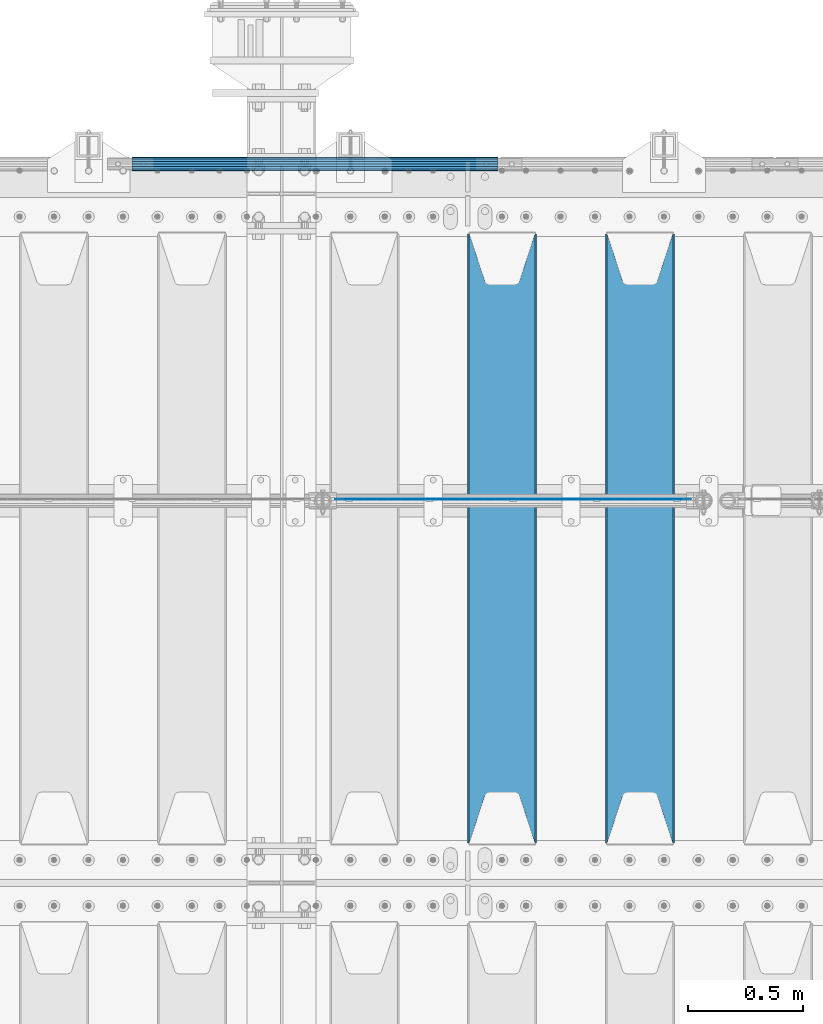
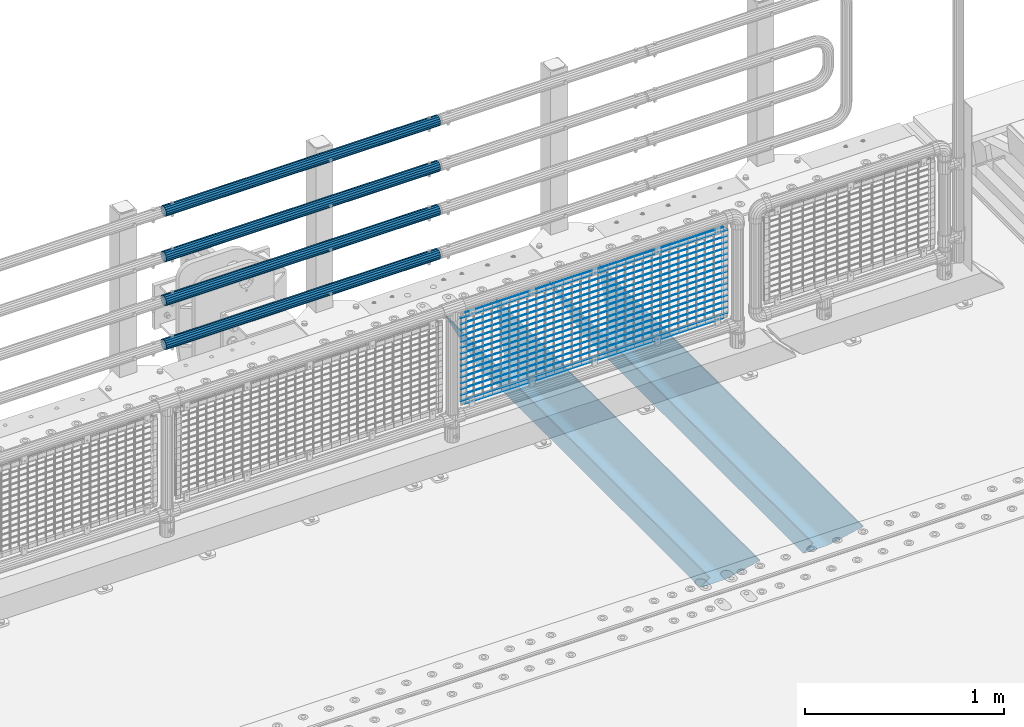
# One storey, part 116 of 219: 23 beams.
"""IFC2X3 building model written with IfcOpenShell, lengths in millimetres."""

import ifcopenshell
import ifcopenshell.guid

model = None  # the IFC model being written
_history = None  # IfcOwnerHistory: only IFC2X3 demands one
_inside = {}  # id of a spatial element -> (the spatial element, [elements in it])
_under = {}  # id of a project, library or spatial element -> (it, [spatial elements below it])
_declared = {}  # id of a project -> (the project, [libraries it declares])
_typed = {}  # id of a type object -> (the type object, [elements of that type])
_made_of = {}  # id of a material, layer set ... -> (it, [elements and type objects made of it])


def new_model(schema):
    """Start an empty IFC model of exactly this schema.

    Asked for "IFC4X3", IfcOpenShell would pick the latest addendum, in which some entities
    have other attributes; the version numbers below select the first issue.
    IFC2X3 requires an IfcOwnerHistory on every rooted entity: one is made here for all.
    """
    global model, _history
    if schema == "IFC4X3":
        model = ifcopenshell.file(schema_version=(4, 3, 0, 0))
    else:
        model = ifcopenshell.file(schema=schema)
    _inside.clear()
    _under.clear()
    _declared.clear()
    _typed.clear()
    _made_of.clear()
    _history = None
    if model.schema == "IFC2X3":
        org = make("IfcOrganization", Name="unknown")
        user = make(
            "IfcPersonAndOrganization",
            ThePerson=make("IfcPerson", FamilyName="unknown"),
            TheOrganization=org,
        )
        app = make(
            "IfcApplication",
            ApplicationDeveloper=org,
            Version="unknown",
            ApplicationFullName="unknown",
            ApplicationIdentifier="unknown",
        )
        _history = make(
            "IfcOwnerHistory",
            OwningUser=user,
            OwningApplication=app,
            ChangeAction="ADDED",
            CreationDate=0,
        )
    return model


def make(cls, **values):
    """One entity of the class cls with the attributes given. An attribute that is None is left unset."""
    return model.create_entity(
        cls, **{name: value for name, value in values.items() if value is not None}
    )


def rooted(cls, **values):
    """An entity with a GlobalId (a new one), such as an element, a storey or a relation."""
    return make(cls, GlobalId=ifcopenshell.guid.new(), OwnerHistory=_history, **values)


def si_unit(unit_type, name, prefix=None):
    """IfcSIUnit, for example si_unit("LENGTHUNIT", "METRE", prefix="MILLI")."""
    return make("IfcSIUnit", UnitType=unit_type, Prefix=prefix, Name=name)


def assignment(units):
    """IfcUnitAssignment: the units of a project."""
    return None if units is None else make("IfcUnitAssignment", Units=units)


def point(xyz):
    """IfcCartesianPoint."""
    return None if xyz is None else make("IfcCartesianPoint", Coordinates=xyz)


def direction(xyz):
    """IfcDirection."""
    return None if xyz is None else make("IfcDirection", DirectionRatios=xyz)


def frame(location, z_axis=None, x_axis=None):
    """IfcAxis2Placement3D, a coordinate frame: its origin and axes. An axis left out is left unset."""
    return make(
        "IfcAxis2Placement3D",
        Location=point(location),
        Axis=direction(z_axis),
        RefDirection=direction(x_axis),
    )


def origin_with_axes():
    """The frame at (0, 0, 0) with the z axis (0, 0, 1) and the x axis (1, 0, 0) written out."""
    return frame((0.0, 0.0, 0.0), z_axis=(0.0, 0.0, 1.0), x_axis=(1.0, 0.0, 0.0))


def place(relative_to, where):
    """IfcLocalPlacement: puts the frame where relative to a parent placement (None: the world)."""
    return make(
        "IfcLocalPlacement", PlacementRelTo=relative_to, RelativePlacement=where
    )


def context(
    kind, dimensions, precision=None, world=None, true_north=None, identifier=None
):
    """IfcGeometricRepresentationContext, for example the 3D "Model" context."""
    return make(
        "IfcGeometricRepresentationContext",
        ContextIdentifier=identifier,
        ContextType=kind,
        CoordinateSpaceDimension=dimensions,
        Precision=precision,
        WorldCoordinateSystem=world,
        TrueNorth=true_north,
    )


def subcontext(parent, identifier, kind, view, scale=None):
    """IfcGeometricRepresentationSubContext, for example "Body" below "Model"."""
    return make(
        "IfcGeometricRepresentationSubContext",
        ContextIdentifier=identifier,
        ContextType=kind,
        ParentContext=parent,
        TargetScale=scale,
        TargetView=view,
    )


def project(units=None, contexts=None):
    """IfcProject with its units and contexts."""
    return rooted(
        "IfcProject",
        Name="project",
        RepresentationContexts=contexts,
        UnitsInContext=assignment(units),
    )


def spatial(cls, under=None, at=None, **own):
    """A site, building, storey or space (cls), placed at a placement, below another one or the project."""
    s = rooted(cls, ObjectPlacement=at, **own)
    if under is not None:
        _under.setdefault(under.id(), (under, []))[1].append(s)
    return s


def faces_of(points, faces, orient=None, outer=None):
    """IfcFace entities. A face is a list of loops; a loop is a list of indices into points, from 0.

    orient and outer hold one flag for each loop. By default every Orientation is true, the
    first loop of a face is its IfcFaceOuterBound and the others are IfcFaceBound.
    """
    made = []
    for i, loops in enumerate(faces):
        bounds = []
        for j, loop in enumerate(loops):
            is_outer = j == 0 if outer is None else outer[i][j]
            bounds.append(
                make(
                    "IfcFaceOuterBound" if is_outer else "IfcFaceBound",
                    Bound=make("IfcPolyLoop", Polygon=[points[k] for k in loop]),
                    Orientation=True if orient is None else orient[i][j],
                )
            )
        made.append(make("IfcFace", Bounds=bounds))
    return made


def faceted_brep(points, faces, orient=None, outer=None, voids=None):
    """IfcFacetedBrep: a solid bounded by flat faces; with voids (closed shells), ...WithVoids."""
    shared = [point(p) for p in points]
    hull = make("IfcClosedShell", CfsFaces=faces_of(shared, faces, orient, outer))
    if voids is None:
        return make("IfcFacetedBrep", Outer=hull)
    return make(
        "IfcFacetedBrepWithVoids",
        Outer=hull,
        Voids=[
            make(cls, CfsFaces=faces_of(shared, fs, o, b)) for cls, fs, o, b in voids
        ],
    )


def shape(context_of_items, identifier, shape_type, items):
    """IfcShapeRepresentation: the items that make up one representation, for example the "Body"."""
    return make(
        "IfcShapeRepresentation",
        ContextOfItems=context_of_items,
        RepresentationIdentifier=identifier,
        RepresentationType=shape_type,
        Items=items,
    )


def material(Name=None, Category=None):
    """IfcMaterial."""
    return make("IfcMaterial", Name=Name, Category=Category)


def made_of(thing, what):
    """Note that an element or type object is made of a material, layer set ...; save() writes the relation."""
    if what is not None:
        _made_of.setdefault(what.id(), (what, []))[1].append(thing)
    return thing


def type_object(cls, material=None, **own):
    """A type object (cls), such as IfcWallType, which elements share."""
    return made_of(rooted(cls, **own), material)


def element(
    cls,
    number,
    at=None,
    inside=None,
    cuts=None,
    type_object=None,
    material=None,
    context=None,
    identifier="Body",
    shape_type=None,
    held_by="IfcProductDefinitionShape",
    body=None,
    shapes=None,
    **own,
):
    """One element of the class cls, such as IfcWall. Its Tag is "e" and its number.

    at: its placement. inside: the storey or other place that contains it. cuts: it is an
    opening in that element (IfcRelVoidsElement). A single representation is given by context,
    identifier, shape_type and body (its items); several are given by shapes. held_by: the class
    of the entity that holds the representations. save() writes the other relations.
    """
    e = rooted(cls, Tag="e%d" % number, ObjectPlacement=at, **own)
    if body is not None:
        shapes = [shape(context, identifier, shape_type, body)]
    if shapes is not None:
        e.Representation = make(held_by, Representations=shapes)
    if inside is not None:
        _inside.setdefault(inside.id(), (inside, []))[1].append(e)
    if cuts is not None:
        rooted(
            "IfcRelVoidsElement", RelatingBuildingElement=cuts, RelatedOpeningElement=e
        )
    if type_object is not None:
        _typed.setdefault(type_object.id(), (type_object, []))[1].append(e)
    return made_of(e, material)


def aggregate(whole, parts):
    """IfcRelAggregates: a whole, such as a stair, and the parts it consists of."""
    return rooted("IfcRelAggregates", RelatingObject=whole, RelatedObjects=parts)


def save(model, path):
    """Write the relations noted so far, then the file.

    IfcRelAggregates (storeys below a building ...), IfcRelContainedInSpatialStructure (elements
    in a storey), IfcRelDefinesByType, IfcRelAssociatesMaterial and IfcRelDeclares: one each for
    every whole, place, type object, material and project.
    """
    for whole, parts in _under.values():
        aggregate(whole, parts)
    for where, things in _inside.values():
        rooted(
            "IfcRelContainedInSpatialStructure",
            RelatedElements=things,
            RelatingStructure=where,
        )
    for kind, things in _typed.values():
        rooted("IfcRelDefinesByType", RelatedObjects=things, RelatingType=kind)
    for what, things in _made_of.values():
        rooted("IfcRelAssociatesMaterial", RelatedObjects=things, RelatingMaterial=what)
    for by, libraries in _declared.values():
        rooted("IfcRelDeclares", RelatingContext=by, RelatedDefinitions=libraries)
    model.write(path)


model = new_model("IFC2X3")

# Units and contexts
model_context = context("Model", 3, precision=1e-05, world=origin_with_axes())
body_context = subcontext(model_context, "Body", "Model", "MODEL_VIEW")
ifc_project = project(units=[si_unit("LENGTHUNIT", "METRE", prefix="MILLI"), si_unit("AREAUNIT", "SQUARE_METRE"), si_unit("VOLUMEUNIT", "CUBIC_METRE"), si_unit("MASSUNIT", "GRAM", prefix="KILO"), si_unit("TIMEUNIT", "SECOND"), si_unit("PLANEANGLEUNIT", "RADIAN"), si_unit("SOLIDANGLEUNIT", "STERADIAN"), si_unit("THERMODYNAMICTEMPERATUREUNIT", "DEGREE_CELSIUS"), si_unit("LUMINOUSINTENSITYUNIT", "LUMEN")], contexts=[model_context])

# Site, building, storey
site_placement = place(None, origin_with_axes())
site = spatial("IfcSite", under=ifc_project, at=site_placement, CompositionType="ELEMENT")
building_placement = place(site_placement, origin_with_axes())
building = spatial("IfcBuilding", under=site, at=building_placement, Name="Standard", CompositionType="ELEMENT")
storey_placement = place(building_placement, origin_with_axes())
storey = spatial("IfcBuildingStorey", under=building, at=storey_placement, Name="Undefined", CompositionType="ELEMENT", Elevation=0.0)

# Beams
ifc_material_1 = material(Name="STEEL/S355N")
beam_type_1 = type_object("IfcBeamType", PredefinedType="NOTDEFINED")
beam_1_placement = place(storey_placement, frame((11950.0, 30175.0, -115.0), z_axis=(0.0, 0.0, 1.0), x_axis=(0.0, 1.0, 0.0)))
element("IfcBeam", 1, at=beam_1_placement, inside=storey, type_object=beam_type_1, material=ifc_material_1, context=body_context, shape_type="Brep", body=[
    faceted_brep([(0.0, 150.0, 115.0), (0.0, 143.690000000001, 115.0), (2650.00000000297, 143.690000000001, 115.0), (2650.00000000297, 150.0, 115.0), (2650.00000000297, 142.0595652184, 110.000000003094), (2650.00000000297, 148.3695652184, 110.000000003094), (2441.90079219209, -80.110360073113, -98.0992078077845), (2437.7588105432, -77.5672621345566, -102.241189456673), (2434.06523489747, -74.4080125315541, -105.934765102404), (2430.9108609509, -70.7102721255742, -109.089139048974), (2428.37322971128, -66.5649389910068, -111.626770288588), (2426.51472138055, -62.0739139532889, -113.485278619323), (2425.38102192092, -57.3475956567672, -114.618978078955), (2424.99999999988, -52.5021667386536, -115.0), (2424.99999999988, 52.5021667386536, -115.0), (2425.38102192092, 57.3475956567672, -114.618978078955), (2426.51472138055, 62.0739139532889, -113.485278619323), (2428.37322971128, 66.5649389910068, -111.626770288588), (2430.9108609509, 70.7102721255742, -109.089139048974), (2434.06523489747, 74.4080125315541, -105.934765102404), (2437.7588105432, 77.5672621345566, -102.241189456673), (2441.90079219209, 80.110360073113, -98.0992078077846), (2446.38936140512, 81.9747917625791, -93.6106385947584), (2448.2494850041, 76.2713538057269, -91.7505149957729), (2444.62967112263, 74.7677798626082, -95.3703288772456), (2441.28936334127, 72.7168944282894, -98.710636658607), (2438.31067330439, 70.1691124903828, -101.689326695487), (2435.76682334748, 67.1870637758839, -104.233176652398), (2433.72034654134, 63.8440531834913, -106.279653458539), (2432.22154950042, 60.2222587982342, -107.778450499454), (2431.30727574265, 56.4107117849107, -108.692724257221), (2430.99999999987, 52.5031078186894, -109.0), (2430.99999999987, -52.5031078186894, -109.0), (2431.30727574265, -56.4107117849107, -108.692724257221), (2432.22154950042, -60.2222587982342, -107.778450499454), (2433.72034654134, -63.8440531834913, -106.279653458539), (2435.76682334748, -67.1870637758839, -104.233176652398), (2438.31067330439, -70.1691124903828, -101.689326695487), (2441.28936334127, -72.7168944282894, -98.7106366586071), (2444.62967112263, -74.7677798626082, -95.3703288772457), (2448.2494850041, -76.2713538057269, -91.7505149957729), (2650.00000000297, -142.0595652184, 110.000000003094), (2650.00000000297, -148.3695652184, 110.000000003094), (2446.38936140512, -81.9747917625791, -93.6106385947584), (2650.00000000297, -143.690000000001, 115.0), (2650.00000000297, -150.0, 115.0), (0.0, -143.690000000001, 115.0), (0.0, -150.0, 115.0), (0.0, -148.369565218261, 110.000000002667), (203.610638597427, -81.9747917625791, -93.6106385947584), (208.09920781045, -80.110360073113, -98.0992078077845), (212.241189459342, -77.5672621345566, -102.241189456673), (215.93476510507, -74.4080125315541, -105.934765102404), (219.089139051641, -70.7102721255742, -109.089139048974), (221.626770291256, -66.5649389910068, -111.626770288588), (223.485278621989, -62.0739139532889, -113.485278619323), (224.618978081624, -57.3475956567672, -114.618978078955), (225.000000002663, -52.5021667386536, -115.0), (225.000000002663, 52.5021667386536, -115.0), (224.618978081624, 57.3475956567672, -114.618978078955), (223.485278621989, 62.0739139532889, -113.485278619323), (221.626770291256, 66.5649389910068, -111.626770288588), (219.089139051641, 70.7102721255742, -109.089139048974), (215.93476510507, 74.4080125315541, -105.934765102404), (212.241189459342, 77.5672621345566, -102.241189456673), (208.09920781045, 80.110360073113, -98.0992078077846), (203.610638597427, 81.9747917625791, -93.6106385947584), (0.0, 148.369565218261, 110.000000002667), (0.0, 142.059565218262, 110.000000002667), (201.750514998439, 76.2713538057269, -91.7505149957729), (205.370328879915, 74.7677798626082, -95.3703288772456), (208.710636661275, 72.7168944282894, -98.710636658607), (211.689326698157, 70.1691124903828, -101.689326695487), (214.233176655063, 67.1870637758839, -104.233176652398), (216.279653461206, 63.8440531834913, -106.279653458539), (217.778450502123, 60.2222587982342, -107.778450499454), (218.69272425989, 56.4107117849107, -108.692724257221), (219.00000000267, 52.5031078186894, -109.0), (219.00000000267, -52.5031078186894, -109.0), (218.69272425989, -56.4107117849107, -108.692724257221), (217.778450502123, -60.2222587982342, -107.778450499454), (216.279653461206, -63.8440531834913, -106.279653458539), (214.233176655063, -67.1870637758839, -104.233176652398), (211.689326698157, -70.1691124903828, -101.689326695487), (208.710636661275, -72.7168944282894, -98.7106366586071), (205.370328879915, -74.7677798626082, -95.3703288772457), (201.750514998439, -76.2713538057269, -91.7505149957729), (0.0, -142.059565218262, 110.000000002667)], [[[0, 1, 2, 3]], [[3, 2, 4, 5]], [[6, 7, 8, 9, 10, 11, 12, 13, 14, 15, 16, 17, 18, 19, 20, 21, 22, 5, 4, 23, 24, 25, 26, 27, 28, 29, 30, 31, 32, 33, 34, 35, 36, 37, 38, 39, 40, 41, 42, 43]], [[44, 45, 42, 41]], [[46, 47, 45, 44]], [[43, 42, 45, 47, 48, 49]], [[6, 43, 49, 50]], [[7, 6, 50, 51]], [[8, 7, 51, 52]], [[9, 8, 52, 53]], [[10, 9, 53, 54]], [[11, 10, 54, 55]], [[12, 11, 55, 56]], [[13, 12, 56, 57]], [[14, 13, 57, 58]], [[15, 14, 58, 59]], [[16, 15, 59, 60]], [[17, 16, 60, 61]], [[18, 17, 61, 62]], [[19, 18, 62, 63]], [[20, 19, 63, 64]], [[21, 20, 64, 65]], [[22, 21, 65, 66]], [[0, 3, 5, 22, 66, 67]], [[1, 0, 67, 68]], [[23, 4, 2, 1, 68, 69]], [[24, 23, 69, 70]], [[25, 24, 70, 71]], [[26, 25, 71, 72]], [[27, 26, 72, 73]], [[28, 27, 73, 74]], [[29, 28, 74, 75]], [[30, 29, 75, 76]], [[31, 30, 76, 77]], [[32, 31, 77, 78]], [[33, 32, 78, 79]], [[34, 33, 79, 80]], [[35, 34, 80, 81]], [[36, 35, 81, 82]], [[37, 36, 82, 83]], [[38, 37, 83, 84]], [[39, 38, 84, 85]], [[40, 39, 85, 86]], [[46, 44, 41, 40, 86, 87]], [[47, 46, 87, 48]], [[86, 85, 84, 83, 82, 81, 80, 79, 78, 77, 76, 75, 74, 73, 72, 71, 70, 69, 68, 67, 66, 65, 64, 63, 62, 61, 60, 59, 58, 57, 56, 55, 54, 53, 52, 51, 50, 49, 48, 87]]]),
])
beam_2_placement = place(storey_placement, frame((11350.0, 30175.0, -115.0), z_axis=(0.0, 0.0, 1.0), x_axis=(0.0, 1.0, 0.0)))
element("IfcBeam", 2, at=beam_2_placement, inside=storey, type_object=beam_type_1, material=ifc_material_1, context=body_context, shape_type="Brep", body=[
    faceted_brep([(0.0, 150.0, 115.0), (0.0, 143.690000000001, 115.0), (2650.00000000297, 143.690000000001, 115.0), (2650.00000000297, 150.0, 115.0), (2650.00000000297, 142.0595652184, 110.000000003094), (2650.00000000297, 148.3695652184, 110.000000003094), (2441.90079219209, -80.110360073113, -98.0992078077845), (2437.7588105432, -77.5672621345566, -102.241189456673), (2434.06523489747, -74.4080125315541, -105.934765102404), (2430.9108609509, -70.7102721255742, -109.089139048974), (2428.37322971128, -66.5649389910068, -111.626770288588), (2426.51472138055, -62.0739139532889, -113.485278619323), (2425.38102192092, -57.3475956567672, -114.618978078955), (2424.99999999988, -52.5021667386536, -115.0), (2424.99999999988, 52.5021667386536, -115.0), (2425.38102192092, 57.3475956567672, -114.618978078955), (2426.51472138055, 62.0739139532889, -113.485278619323), (2428.37322971128, 66.5649389910068, -111.626770288588), (2430.9108609509, 70.7102721255742, -109.089139048974), (2434.06523489747, 74.4080125315541, -105.934765102404), (2437.7588105432, 77.5672621345566, -102.241189456673), (2441.90079219209, 80.110360073113, -98.0992078077846), (2446.38936140512, 81.9747917625791, -93.6106385947584), (2448.2494850041, 76.2713538057269, -91.7505149957729), (2444.62967112263, 74.7677798626082, -95.3703288772456), (2441.28936334127, 72.7168944282894, -98.710636658607), (2438.31067330439, 70.1691124903828, -101.689326695487), (2435.76682334748, 67.1870637758839, -104.233176652398), (2433.72034654134, 63.8440531834913, -106.279653458539), (2432.22154950042, 60.2222587982342, -107.778450499454), (2431.30727574265, 56.4107117849107, -108.692724257221), (2430.99999999987, 52.5031078186894, -109.0), (2430.99999999987, -52.5031078186894, -109.0), (2431.30727574265, -56.4107117849107, -108.692724257221), (2432.22154950042, -60.2222587982342, -107.778450499454), (2433.72034654134, -63.8440531834913, -106.279653458539), (2435.76682334748, -67.1870637758839, -104.233176652398), (2438.31067330439, -70.1691124903828, -101.689326695487), (2441.28936334127, -72.7168944282894, -98.7106366586071), (2444.62967112263, -74.7677798626082, -95.3703288772457), (2448.2494850041, -76.2713538057269, -91.7505149957729), (2650.00000000297, -142.0595652184, 110.000000003094), (2650.00000000297, -148.3695652184, 110.000000003094), (2446.38936140512, -81.9747917625791, -93.6106385947584), (2650.00000000297, -143.690000000001, 115.0), (2650.00000000297, -150.0, 115.0), (0.0, -143.690000000001, 115.0), (0.0, -150.0, 115.0), (0.0, -148.369565218261, 110.000000002667), (203.610638597427, -81.9747917625791, -93.6106385947584), (208.09920781045, -80.110360073113, -98.0992078077845), (212.241189459342, -77.5672621345566, -102.241189456673), (215.93476510507, -74.4080125315541, -105.934765102404), (219.089139051641, -70.7102721255742, -109.089139048974), (221.626770291256, -66.5649389910068, -111.626770288588), (223.485278621989, -62.0739139532889, -113.485278619323), (224.618978081624, -57.3475956567672, -114.618978078955), (225.000000002663, -52.5021667386536, -115.0), (225.000000002663, 52.5021667386536, -115.0), (224.618978081624, 57.3475956567672, -114.618978078955), (223.485278621989, 62.0739139532889, -113.485278619323), (221.626770291256, 66.5649389910068, -111.626770288588), (219.089139051641, 70.7102721255742, -109.089139048974), (215.93476510507, 74.4080125315541, -105.934765102404), (212.241189459342, 77.5672621345566, -102.241189456673), (208.09920781045, 80.110360073113, -98.0992078077846), (203.610638597427, 81.9747917625791, -93.6106385947584), (0.0, 148.369565218261, 110.000000002667), (0.0, 142.059565218262, 110.000000002667), (201.750514998439, 76.2713538057269, -91.7505149957729), (205.370328879915, 74.7677798626082, -95.3703288772456), (208.710636661275, 72.7168944282894, -98.710636658607), (211.689326698157, 70.1691124903828, -101.689326695487), (214.233176655063, 67.1870637758839, -104.233176652398), (216.279653461206, 63.8440531834913, -106.279653458539), (217.778450502123, 60.2222587982342, -107.778450499454), (218.69272425989, 56.4107117849107, -108.692724257221), (219.00000000267, 52.5031078186894, -109.0), (219.00000000267, -52.5031078186894, -109.0), (218.69272425989, -56.4107117849107, -108.692724257221), (217.778450502123, -60.2222587982342, -107.778450499454), (216.279653461206, -63.8440531834913, -106.279653458539), (214.233176655063, -67.1870637758839, -104.233176652398), (211.689326698157, -70.1691124903828, -101.689326695487), (208.710636661275, -72.7168944282894, -98.7106366586071), (205.370328879915, -74.7677798626082, -95.3703288772457), (201.750514998439, -76.2713538057269, -91.7505149957729), (0.0, -142.059565218262, 110.000000002667)], [[[0, 1, 2, 3]], [[3, 2, 4, 5]], [[6, 7, 8, 9, 10, 11, 12, 13, 14, 15, 16, 17, 18, 19, 20, 21, 22, 5, 4, 23, 24, 25, 26, 27, 28, 29, 30, 31, 32, 33, 34, 35, 36, 37, 38, 39, 40, 41, 42, 43]], [[44, 45, 42, 41]], [[46, 47, 45, 44]], [[43, 42, 45, 47, 48, 49]], [[6, 43, 49, 50]], [[7, 6, 50, 51]], [[8, 7, 51, 52]], [[9, 8, 52, 53]], [[10, 9, 53, 54]], [[11, 10, 54, 55]], [[12, 11, 55, 56]], [[13, 12, 56, 57]], [[14, 13, 57, 58]], [[15, 14, 58, 59]], [[16, 15, 59, 60]], [[17, 16, 60, 61]], [[18, 17, 61, 62]], [[19, 18, 62, 63]], [[20, 19, 63, 64]], [[21, 20, 64, 65]], [[22, 21, 65, 66]], [[0, 3, 5, 22, 66, 67]], [[1, 0, 67, 68]], [[23, 4, 2, 1, 68, 69]], [[24, 23, 69, 70]], [[25, 24, 70, 71]], [[26, 25, 71, 72]], [[27, 26, 72, 73]], [[28, 27, 73, 74]], [[29, 28, 74, 75]], [[30, 29, 75, 76]], [[31, 30, 76, 77]], [[32, 31, 77, 78]], [[33, 32, 78, 79]], [[34, 33, 79, 80]], [[35, 34, 80, 81]], [[36, 35, 81, 82]], [[37, 36, 82, 83]], [[38, 37, 83, 84]], [[39, 38, 84, 85]], [[40, 39, 85, 86]], [[46, 44, 41, 40, 86, 87]], [[47, 46, 87, 48]], [[86, 85, 84, 83, 82, 81, 80, 79, 78, 77, 76, 75, 74, 73, 72, 71, 70, 69, 68, 67, 66, 65, 64, 63, 62, 61, 60, 59, 58, 57, 56, 55, 54, 53, 52, 51, 50, 49, 48, 87]]]),
])
ifc_material_2 = material(Name="Misc_Undefined")
beam_type_2 = type_object("IfcBeamType", Name="D3", PredefinedType="NOTDEFINED")
for number, where, z_axis, x_axis in (
    (3, (10624.0, 31670.5, 851.597000000001), (0.0, 0.0, 1.0), (1.0, 0.0, 0.0)),
    (4, (10624.0, 31670.5, 669.452000000001), (0.0, 0.0, 1.0), (1.0, 0.0, 0.0)),
    (5, (10624.0, 31670.5, 523.736000000001), (0.0, 0.0, 1.0), (1.0, 0.0, 0.0)),
    (6, (10624.0, 31670.5, 487.307000000001), (0.0, 0.0, 1.0), (1.0, 0.0, 0.0)),
    (7, (10624.0, 31670.5, 705.881000000001), (0.0, 0.0, 1.0), (1.0, 0.0, 0.0)),
    (8, (10624.0, 31670.5, 596.594000000001), (0.0, 0.0, 1.0), (1.0, 0.0, 0.0)),
    (9, (10624.0, 31670.5, 450.878000000001), (0.0, 0.0, 1.0), (1.0, 0.0, 0.0)),
    (10, (10624.0, 31670.5, 815.168000000001), (0.0, 0.0, 1.0), (1.0, 0.0, 0.0)),
    (11, (10624.0, 31670.5, 888.026000000001), (0.0, 0.0, 1.0), (1.0, 0.0, 0.0)),
    (12, (10624.0, 31670.5, 778.739000000001), (0.0, 0.0, 1.0), (1.0, 0.0, 0.0)),
    (13, (10624.0, 31670.5, 742.310000000001), (0.0, 0.0, 1.0), (1.0, 0.0, 0.0)),
    (14, (10624.0, 31670.5, 633.023000000001), (0.0, 0.0, 1.0), (1.0, 0.0, 0.0)),
    (15, (10624.0, 31670.5, 560.165000000001), (0.0, 0.0, 1.0), (1.0, 0.0, 0.0)),
    (16, (10624.0, 31670.5, 414.449000000001), (0.0, 0.0, 1.0), (1.0, 0.0, 0.0)),
):
    element("IfcBeam", number, at=place(storey_placement, frame(where, z_axis=z_axis, x_axis=x_axis)), inside=storey, type_object=beam_type_2, material=ifc_material_2, ObjectType="D3", context=body_context, shape_type="Brep", body=[
        faceted_brep([(0.0, -1.5, -5.6843418860808e-14), (0.0, -0.75, -1.29903810567669), (1548.0, -0.75, -1.29903810567669), (1548.0, -1.5, 0.0), (0.0, 0.75, -1.29903810567669), (1548.0, 0.75, -1.29903810567669), (0.0, 1.5, -5.6843418860808e-14), (1548.0, 1.5, 0.0), (0.0, 0.75, 1.29903810567669), (1548.0, 0.75, 1.29903810567669), (0.0, -0.75, 1.29903810567669), (1548.0, -0.75, 1.29903810567669)], [[[0, 1, 2, 3]], [[1, 4, 5, 2]], [[4, 6, 7, 5]], [[6, 8, 9, 7]], [[8, 10, 11, 9]], [[10, 0, 3, 11]], [[5, 7, 9, 11, 3, 2]], [[10, 8, 6, 4, 1, 0]]]),
    ])
beam_3_placement = place(storey_placement, frame((10649.0, 31670.5, 353.020000000001), z_axis=(0.0, 0.0, 1.0), x_axis=(1.0, 0.0, 0.0)))
element("IfcBeam", 17, at=beam_3_placement, inside=storey, type_object=beam_type_2, material=ifc_material_2, ObjectType="D3", context=body_context, shape_type="Brep", body=[
    faceted_brep([(0.0, -1.5, -5.6843418860808e-14), (0.0, -0.75, -1.29903810567669), (1498.0, -0.75, -1.29903810567669), (1498.0, -1.5, 0.0), (0.0, 0.75, -1.29903810567669), (1498.0, 0.75, -1.29903810567663), (0.0, 1.5, -5.6843418860808e-14), (1498.0, 1.5, 0.0), (0.0, 0.75, 1.29903810567669), (1498.0, 0.75, 1.29903810567669), (0.0, -0.75, 1.29903810567669), (1498.0, -0.75, 1.29903810567669)], [[[0, 1, 2, 3]], [[1, 4, 5, 2]], [[4, 6, 7, 5]], [[6, 8, 9, 7]], [[8, 10, 11, 9]], [[10, 0, 3, 11]], [[5, 7, 9, 11, 3, 2]], [[10, 8, 6, 4, 1, 0]]]),
])
beam_4_placement = place(storey_placement, frame((10624.0, 31670.5, 378.020000000001), z_axis=(0.0, 0.0, 1.0), x_axis=(1.0, 0.0, 0.0)))
element("IfcBeam", 18, at=beam_4_placement, inside=storey, type_object=beam_type_2, material=ifc_material_2, ObjectType="D3", context=body_context, shape_type="Brep", body=[
    faceted_brep([(0.0, -1.5, -5.6843418860808e-14), (0.0, -0.75, -1.29903810567669), (1548.0, -0.75, -1.29903810567669), (1548.0, -1.5, 0.0), (0.0, 0.75, -1.29903810567669), (1548.0, 0.75, -1.29903810567669), (0.0, 1.5, -5.6843418860808e-14), (1548.0, 1.5, 0.0), (0.0, 0.75, 1.29903810567669), (1548.0, 0.75, 1.29903810567669), (0.0, -0.75, 1.29903810567669), (1548.0, -0.75, 1.29903810567669)], [[[0, 1, 2, 3]], [[1, 4, 5, 2]], [[4, 6, 7, 5]], [[6, 8, 9, 7]], [[8, 10, 11, 9]], [[10, 0, 3, 11]], [[5, 7, 9, 11, 3, 2]], [[10, 8, 6, 4, 1, 0]]]),
])
beam_5_placement = place(storey_placement, frame((10649.0, 31670.5, 913.020000000001), z_axis=(0.0, 0.0, 1.0), x_axis=(1.0, 0.0, 0.0)))
element("IfcBeam", 19, at=beam_5_placement, inside=storey, type_object=beam_type_2, material=ifc_material_2, ObjectType="D3", context=body_context, shape_type="Brep", body=[
    faceted_brep([(0.0, -1.5, -5.6843418860808e-14), (0.0, -0.75, -1.29903810567669), (1498.0, -0.75, -1.29903810567669), (1498.0, -1.5, 0.0), (0.0, 0.75, -1.29903810567669), (1498.0, 0.75, -1.29903810567663), (0.0, 1.5, -5.6843418860808e-14), (1498.0, 1.5, 0.0), (0.0, 0.75, 1.29903810567669), (1498.0, 0.75, 1.29903810567669), (0.0, -0.75, 1.29903810567669), (1498.0, -0.75, 1.29903810567669)], [[[0, 1, 2, 3]], [[1, 4, 5, 2]], [[4, 6, 7, 5]], [[6, 8, 9, 7]], [[8, 10, 11, 9]], [[10, 0, 3, 11]], [[5, 7, 9, 11, 3, 2]], [[10, 8, 6, 4, 1, 0]]]),
])
ifc_material_3 = material()
beam_type_3 = type_object("IfcBeamType", PredefinedType="NOTDEFINED")
beam_6_placement = place(storey_placement, frame((11331.9999999999, 33129.8500000002, 149.849999999748), z_axis=(0.0, 0.0, -1.0), x_axis=(-1.0, 0.0, 0.0)))
element("IfcBeam", 20, at=beam_6_placement, inside=storey, type_object=beam_type_3, material=ifc_material_3, context=body_context, shape_type="Brep", body=[
    faceted_brep([(0.0, -26.5500000000029, 0.0), (0.0, -24.5290015881765, 10.1602451292931), (1594.0, -24.5290015881765, 10.1602451292931), (1594.0, -26.5500000000029, 0.0), (0.0, -18.7736850405054, 18.7736850405028), (1594.0, -18.7736850405054, 18.7736850405028), (0.0, -10.1602451292929, 24.5290015881747), (1594.0, -10.1602451292929, 24.5290015881747), (0.0, 0.0, 26.55), (1594.0, 0.0, 26.55), (0.0, 10.1602451292929, 24.5290015881747), (1594.0, 10.1602451292929, 24.5290015881747), (0.0, 18.7736850405054, 18.7736850405028), (1594.0, 18.7736850405054, 18.7736850405028), (0.0, 24.5290015881765, 10.1602451292931), (1594.0, 24.5290015881765, 10.1602451292931), (0.0, 26.5500000000029, 0.0), (1594.0, 26.5500000000029, 0.0), (0.0, 24.5290015881765, -10.1602451292931), (1594.0, 24.5290015881765, -10.1602451292931), (0.0, 18.7736850405054, -18.7736850405028), (1594.0, 18.7736850405054, -18.7736850405028), (0.0, 10.1602451292929, -24.5290015881747), (1594.0, 10.1602451292929, -24.5290015881747), (0.0, 0.0, -26.55), (1594.0, 0.0, -26.55), (0.0, -10.1602451292929, -24.5290015881747), (1594.0, -10.1602451292929, -24.5290015881747), (0.0, -18.7736850405054, -18.7736850405028), (1594.0, -18.7736850405054, -18.7736850405028), (0.0, -24.5290015881765, -10.1602451292931), (1594.0, -24.5290015881765, -10.1602451292931), (0.0, -30.1500000000015, 0.0), (0.0, -27.8549679052157, -11.5379054858076), (1594.0, -27.8549679052157, -11.5379054858075), (1594.0, -30.1500000000015, 0.0), (0.0, -21.3192694527752, -21.3192694527752), (1594.0, -21.3192694527752, -21.3192694527744), (0.0, -11.5379054858058, -27.8549679052157), (1594.0, -11.5379054858058, -27.8549679052153), (0.0, 0.0, -30.1499999999996), (1594.0, 0.0, -30.15), (0.0, 11.5379054858058, -27.8549679052157), (1594.0, 11.5379054858058, -27.8549679052153), (0.0, 21.3192694527752, -21.3192694527752), (1594.0, 21.3192694527752, -21.3192694527744), (0.0, 27.8549679052157, -11.5379054858076), (1594.0, 27.8549679052157, -11.5379054858074), (0.0, 30.1500000000015, 0.0), (1594.0, 30.1500000000015, 0.0), (0.0, 27.8549679052157, 11.5379054858076), (1594.0, 27.8549679052157, 11.5379054858075), (0.0, 21.3192694527752, 21.3192694527752), (1594.0, 21.3192694527752, 21.3192694527744), (0.0, 11.5379054858058, 27.8549679052157), (1594.0, 11.5379054858058, 27.8549679052153), (0.0, 0.0, 30.1499999999996), (1594.0, 0.0, 30.15), (0.0, -11.5379054858058, 27.8549679052157), (1594.0, -11.5379054858058, 27.8549679052153), (0.0, -21.3192694527752, 21.3192694527752), (1594.0, -21.3192694527752, 21.3192694527744), (0.0, -27.8549679052157, 11.5379054858076), (1594.0, -27.8549679052157, 11.5379054858075)], [[[0, 1, 2, 3]], [[1, 4, 5, 2]], [[4, 6, 7, 5]], [[6, 8, 9, 7]], [[8, 10, 11, 9]], [[10, 12, 13, 11]], [[12, 14, 15, 13]], [[14, 16, 17, 15]], [[16, 18, 19, 17]], [[18, 20, 21, 19]], [[20, 22, 23, 21]], [[22, 24, 25, 23]], [[24, 26, 27, 25]], [[26, 28, 29, 27]], [[28, 30, 31, 29]], [[30, 0, 3, 31]], [[32, 33, 34, 35]], [[33, 36, 37, 34]], [[36, 38, 39, 37]], [[38, 40, 41, 39]], [[40, 42, 43, 41]], [[42, 44, 45, 43]], [[44, 46, 47, 45]], [[46, 48, 49, 47]], [[48, 50, 51, 49]], [[50, 52, 53, 51]], [[52, 54, 55, 53]], [[54, 56, 57, 55]], [[56, 58, 59, 57]], [[58, 60, 61, 59]], [[60, 62, 63, 61]], [[62, 32, 35, 63]], [[37, 39, 41, 43, 45, 47, 49, 51, 53, 55, 57, 59, 61, 63, 35, 34], [5, 7, 9, 11, 13, 15, 17, 19, 21, 23, 25, 27, 29, 31, 3, 2]], [[62, 60, 58, 56, 54, 52, 50, 48, 46, 44, 42, 40, 38, 36, 33, 32], [30, 28, 26, 24, 22, 20, 18, 16, 14, 12, 10, 8, 6, 4, 1, 0]]]),
])
beam_7_placement = place(storey_placement, frame((11331.9999999999, 33129.8500000002, 420.149999999748), z_axis=(0.0, 0.0, -1.0), x_axis=(-1.0, 0.0, 0.0)))
element("IfcBeam", 21, at=beam_7_placement, inside=storey, type_object=beam_type_3, material=ifc_material_3, context=body_context, shape_type="Brep", body=[
    faceted_brep([(0.0, -26.5500000000029, 0.0), (0.0, -24.5290015881765, 10.1602451292931), (1594.0, -24.5290015881765, 10.1602451292931), (1594.0, -26.5500000000029, 0.0), (0.0, -18.7736850405054, 18.7736850405028), (1594.0, -18.7736850405054, 18.7736850405028), (0.0, -10.1602451292929, 24.5290015881747), (1594.0, -10.1602451292929, 24.5290015881747), (0.0, 0.0, 26.55), (1594.0, 0.0, 26.55), (0.0, 10.1602451292929, 24.5290015881747), (1594.0, 10.1602451292929, 24.5290015881747), (0.0, 18.7736850405054, 18.7736850405028), (1594.0, 18.7736850405054, 18.7736850405028), (0.0, 24.5290015881765, 10.1602451292931), (1594.0, 24.5290015881765, 10.1602451292931), (0.0, 26.5500000000029, 0.0), (1594.0, 26.5500000000029, 0.0), (0.0, 24.5290015881765, -10.1602451292931), (1594.0, 24.5290015881765, -10.1602451292931), (0.0, 18.7736850405054, -18.7736850405028), (1594.0, 18.7736850405054, -18.7736850405028), (0.0, 10.1602451292929, -24.5290015881747), (1594.0, 10.1602451292929, -24.5290015881747), (0.0, 0.0, -26.55), (1594.0, 0.0, -26.55), (0.0, -10.1602451292929, -24.5290015881747), (1594.0, -10.1602451292929, -24.5290015881747), (0.0, -18.7736850405054, -18.7736850405028), (1594.0, -18.7736850405054, -18.7736850405028), (0.0, -24.5290015881765, -10.1602451292931), (1594.0, -24.5290015881765, -10.1602451292931), (0.0, -30.1500000000015, 0.0), (0.0, -27.8549679052157, -11.5379054858076), (1594.0, -27.8549679052157, -11.5379054858075), (1594.0, -30.1500000000015, 0.0), (0.0, -21.3192694527752, -21.3192694527752), (1594.0, -21.3192694527752, -21.3192694527744), (0.0, -11.5379054858058, -27.8549679052157), (1594.0, -11.5379054858058, -27.8549679052153), (0.0, 0.0, -30.1499999999996), (1594.0, 0.0, -30.15), (0.0, 11.5379054858058, -27.8549679052157), (1594.0, 11.5379054858058, -27.8549679052153), (0.0, 21.3192694527752, -21.3192694527752), (1594.0, 21.3192694527752, -21.3192694527744), (0.0, 27.8549679052157, -11.5379054858076), (1594.0, 27.8549679052157, -11.5379054858074), (0.0, 30.1500000000015, 0.0), (1594.0, 30.1500000000015, 0.0), (0.0, 27.8549679052157, 11.5379054858076), (1594.0, 27.8549679052157, 11.5379054858075), (0.0, 21.3192694527752, 21.3192694527752), (1594.0, 21.3192694527752, 21.3192694527744), (0.0, 11.5379054858058, 27.8549679052157), (1594.0, 11.5379054858058, 27.8549679052153), (0.0, 0.0, 30.1499999999996), (1594.0, 0.0, 30.15), (0.0, -11.5379054858058, 27.8549679052157), (1594.0, -11.5379054858058, 27.8549679052153), (0.0, -21.3192694527752, 21.3192694527752), (1594.0, -21.3192694527752, 21.3192694527744), (0.0, -27.8549679052157, 11.5379054858076), (1594.0, -27.8549679052157, 11.5379054858075)], [[[0, 1, 2, 3]], [[1, 4, 5, 2]], [[4, 6, 7, 5]], [[6, 8, 9, 7]], [[8, 10, 11, 9]], [[10, 12, 13, 11]], [[12, 14, 15, 13]], [[14, 16, 17, 15]], [[16, 18, 19, 17]], [[18, 20, 21, 19]], [[20, 22, 23, 21]], [[22, 24, 25, 23]], [[24, 26, 27, 25]], [[26, 28, 29, 27]], [[28, 30, 31, 29]], [[30, 0, 3, 31]], [[32, 33, 34, 35]], [[33, 36, 37, 34]], [[36, 38, 39, 37]], [[38, 40, 41, 39]], [[40, 42, 43, 41]], [[42, 44, 45, 43]], [[44, 46, 47, 45]], [[46, 48, 49, 47]], [[48, 50, 51, 49]], [[50, 52, 53, 51]], [[52, 54, 55, 53]], [[54, 56, 57, 55]], [[56, 58, 59, 57]], [[58, 60, 61, 59]], [[60, 62, 63, 61]], [[62, 32, 35, 63]], [[37, 39, 41, 43, 45, 47, 49, 51, 53, 55, 57, 59, 61, 63, 35, 34], [5, 7, 9, 11, 13, 15, 17, 19, 21, 23, 25, 27, 29, 31, 3, 2]], [[62, 60, 58, 56, 54, 52, 50, 48, 46, 44, 42, 40, 38, 36, 33, 32], [30, 28, 26, 24, 22, 20, 18, 16, 14, 12, 10, 8, 6, 4, 1, 0]]]),
])
beam_8_placement = place(storey_placement, frame((11331.9999999999, 33129.8500000002, 969.849999999748), z_axis=(0.0, 0.0, -1.0), x_axis=(-1.0, 0.0, 0.0)))
element("IfcBeam", 22, at=beam_8_placement, inside=storey, type_object=beam_type_3, material=ifc_material_3, context=body_context, shape_type="Brep", body=[
    faceted_brep([(0.0, -26.5500000000029, 0.0), (0.0, -24.5290015881765, 10.1602451292931), (1594.0, -24.5290015881765, 10.1602451292931), (1594.0, -26.5500000000029, 0.0), (0.0, -18.7736850405054, 18.7736850405028), (1594.0, -18.7736850405054, 18.7736850405028), (0.0, -10.1602451292929, 24.5290015881747), (1594.0, -10.1602451292929, 24.5290015881747), (0.0, 0.0, 26.55), (1594.0, 0.0, 26.55), (0.0, 10.1602451292929, 24.5290015881747), (1594.0, 10.1602451292929, 24.5290015881747), (0.0, 18.7736850405054, 18.7736850405028), (1594.0, 18.7736850405054, 18.7736850405028), (0.0, 24.5290015881765, 10.1602451292931), (1594.0, 24.5290015881765, 10.1602451292931), (0.0, 26.5500000000029, 0.0), (1594.0, 26.5500000000029, 0.0), (0.0, 24.5290015881765, -10.1602451292931), (1594.0, 24.5290015881765, -10.1602451292931), (0.0, 18.7736850405054, -18.7736850405028), (1594.0, 18.7736850405054, -18.7736850405028), (0.0, 10.1602451292929, -24.5290015881747), (1594.0, 10.1602451292929, -24.5290015881747), (0.0, 0.0, -26.55), (1594.0, 0.0, -26.55), (0.0, -10.1602451292929, -24.5290015881747), (1594.0, -10.1602451292929, -24.5290015881747), (0.0, -18.7736850405054, -18.7736850405028), (1594.0, -18.7736850405054, -18.7736850405028), (0.0, -24.5290015881765, -10.1602451292931), (1594.0, -24.5290015881765, -10.1602451292931), (0.0, -30.1500000000015, 0.0), (0.0, -27.8549679052157, -11.5379054858076), (1594.0, -27.8549679052157, -11.5379054858075), (1594.0, -30.1500000000015, 0.0), (0.0, -21.3192694527752, -21.3192694527752), (1594.0, -21.3192694527752, -21.3192694527744), (0.0, -11.5379054858058, -27.8549679052157), (1594.0, -11.5379054858058, -27.8549679052153), (0.0, 0.0, -30.1499999999996), (1594.0, 0.0, -30.15), (0.0, 11.5379054858058, -27.8549679052157), (1594.0, 11.5379054858058, -27.8549679052153), (0.0, 21.3192694527752, -21.3192694527752), (1594.0, 21.3192694527752, -21.3192694527744), (0.0, 27.8549679052157, -11.5379054858076), (1594.0, 27.8549679052157, -11.5379054858074), (0.0, 30.1500000000015, 0.0), (1594.0, 30.1500000000015, 0.0), (0.0, 27.8549679052157, 11.5379054858076), (1594.0, 27.8549679052157, 11.5379054858075), (0.0, 21.3192694527752, 21.3192694527752), (1594.0, 21.3192694527752, 21.3192694527744), (0.0, 11.5379054858058, 27.8549679052157), (1594.0, 11.5379054858058, 27.8549679052153), (0.0, 0.0, 30.1499999999996), (1594.0, 0.0, 30.15), (0.0, -11.5379054858058, 27.8549679052157), (1594.0, -11.5379054858058, 27.8549679052153), (0.0, -21.3192694527752, 21.3192694527752), (1594.0, -21.3192694527752, 21.3192694527744), (0.0, -27.8549679052157, 11.5379054858076), (1594.0, -27.8549679052157, 11.5379054858075)], [[[0, 1, 2, 3]], [[1, 4, 5, 2]], [[4, 6, 7, 5]], [[6, 8, 9, 7]], [[8, 10, 11, 9]], [[10, 12, 13, 11]], [[12, 14, 15, 13]], [[14, 16, 17, 15]], [[16, 18, 19, 17]], [[18, 20, 21, 19]], [[20, 22, 23, 21]], [[22, 24, 25, 23]], [[24, 26, 27, 25]], [[26, 28, 29, 27]], [[28, 30, 31, 29]], [[30, 0, 3, 31]], [[32, 33, 34, 35]], [[33, 36, 37, 34]], [[36, 38, 39, 37]], [[38, 40, 41, 39]], [[40, 42, 43, 41]], [[42, 44, 45, 43]], [[44, 46, 47, 45]], [[46, 48, 49, 47]], [[48, 50, 51, 49]], [[50, 52, 53, 51]], [[52, 54, 55, 53]], [[54, 56, 57, 55]], [[56, 58, 59, 57]], [[58, 60, 61, 59]], [[60, 62, 63, 61]], [[62, 32, 35, 63]], [[37, 39, 41, 43, 45, 47, 49, 51, 53, 55, 57, 59, 61, 63, 35, 34], [5, 7, 9, 11, 13, 15, 17, 19, 21, 23, 25, 27, 29, 31, 3, 2]], [[62, 60, 58, 56, 54, 52, 50, 48, 46, 44, 42, 40, 38, 36, 33, 32], [30, 28, 26, 24, 22, 20, 18, 16, 14, 12, 10, 8, 6, 4, 1, 0]]]),
])
beam_9_placement = place(storey_placement, frame((11331.9999999999, 33129.8500000002, 689.849999999748), z_axis=(0.0, 0.0, -1.0), x_axis=(-1.0, 0.0, 0.0)))
element("IfcBeam", 23, at=beam_9_placement, inside=storey, type_object=beam_type_3, material=ifc_material_3, context=body_context, shape_type="Brep", body=[
    faceted_brep([(0.0, -26.5500000000029, 0.0), (0.0, -24.5290015881765, 10.1602451292931), (1594.0, -24.5290015881765, 10.1602451292931), (1594.0, -26.5500000000029, 0.0), (0.0, -18.7736850405054, 18.7736850405028), (1594.0, -18.7736850405054, 18.7736850405028), (0.0, -10.1602451292929, 24.5290015881747), (1594.0, -10.1602451292929, 24.5290015881747), (0.0, 0.0, 26.55), (1594.0, 0.0, 26.55), (0.0, 10.1602451292929, 24.5290015881747), (1594.0, 10.1602451292929, 24.5290015881747), (0.0, 18.7736850405054, 18.7736850405028), (1594.0, 18.7736850405054, 18.7736850405028), (0.0, 24.5290015881765, 10.1602451292931), (1594.0, 24.5290015881765, 10.1602451292931), (0.0, 26.5500000000029, 0.0), (1594.0, 26.5500000000029, 0.0), (0.0, 24.5290015881765, -10.1602451292931), (1594.0, 24.5290015881765, -10.1602451292931), (0.0, 18.7736850405054, -18.7736850405028), (1594.0, 18.7736850405054, -18.7736850405028), (0.0, 10.1602451292929, -24.5290015881747), (1594.0, 10.1602451292929, -24.5290015881747), (0.0, 0.0, -26.55), (1594.0, 0.0, -26.55), (0.0, -10.1602451292929, -24.5290015881747), (1594.0, -10.1602451292929, -24.5290015881747), (0.0, -18.7736850405054, -18.7736850405028), (1594.0, -18.7736850405054, -18.7736850405028), (0.0, -24.5290015881765, -10.1602451292931), (1594.0, -24.5290015881765, -10.1602451292931), (0.0, -30.1500000000015, 0.0), (0.0, -27.8549679052157, -11.5379054858076), (1594.0, -27.8549679052157, -11.5379054858075), (1594.0, -30.1500000000015, 0.0), (0.0, -21.3192694527752, -21.3192694527752), (1594.0, -21.3192694527752, -21.3192694527744), (0.0, -11.5379054858058, -27.8549679052157), (1594.0, -11.5379054858058, -27.8549679052153), (0.0, 0.0, -30.1499999999996), (1594.0, 0.0, -30.15), (0.0, 11.5379054858058, -27.8549679052157), (1594.0, 11.5379054858058, -27.8549679052153), (0.0, 21.3192694527752, -21.3192694527752), (1594.0, 21.3192694527752, -21.3192694527744), (0.0, 27.8549679052157, -11.5379054858076), (1594.0, 27.8549679052157, -11.5379054858074), (0.0, 30.1500000000015, 0.0), (1594.0, 30.1500000000015, 0.0), (0.0, 27.8549679052157, 11.5379054858076), (1594.0, 27.8549679052157, 11.5379054858075), (0.0, 21.3192694527752, 21.3192694527752), (1594.0, 21.3192694527752, 21.3192694527744), (0.0, 11.5379054858058, 27.8549679052157), (1594.0, 11.5379054858058, 27.8549679052153), (0.0, 0.0, 30.1499999999996), (1594.0, 0.0, 30.15), (0.0, -11.5379054858058, 27.8549679052157), (1594.0, -11.5379054858058, 27.8549679052153), (0.0, -21.3192694527752, 21.3192694527752), (1594.0, -21.3192694527752, 21.3192694527744), (0.0, -27.8549679052157, 11.5379054858076), (1594.0, -27.8549679052157, 11.5379054858075)], [[[0, 1, 2, 3]], [[1, 4, 5, 2]], [[4, 6, 7, 5]], [[6, 8, 9, 7]], [[8, 10, 11, 9]], [[10, 12, 13, 11]], [[12, 14, 15, 13]], [[14, 16, 17, 15]], [[16, 18, 19, 17]], [[18, 20, 21, 19]], [[20, 22, 23, 21]], [[22, 24, 25, 23]], [[24, 26, 27, 25]], [[26, 28, 29, 27]], [[28, 30, 31, 29]], [[30, 0, 3, 31]], [[32, 33, 34, 35]], [[33, 36, 37, 34]], [[36, 38, 39, 37]], [[38, 40, 41, 39]], [[40, 42, 43, 41]], [[42, 44, 45, 43]], [[44, 46, 47, 45]], [[46, 48, 49, 47]], [[48, 50, 51, 49]], [[50, 52, 53, 51]], [[52, 54, 55, 53]], [[54, 56, 57, 55]], [[56, 58, 59, 57]], [[58, 60, 61, 59]], [[60, 62, 63, 61]], [[62, 32, 35, 63]], [[37, 39, 41, 43, 45, 47, 49, 51, 53, 55, 57, 59, 61, 63, 35, 34], [5, 7, 9, 11, 13, 15, 17, 19, 21, 23, 25, 27, 29, 31, 3, 2]], [[62, 60, 58, 56, 54, 52, 50, 48, 46, 44, 42, 40, 38, 36, 33, 32], [30, 28, 26, 24, 22, 20, 18, 16, 14, 12, 10, 8, 6, 4, 1, 0]]]),
])

save(model, "model.ifc")
